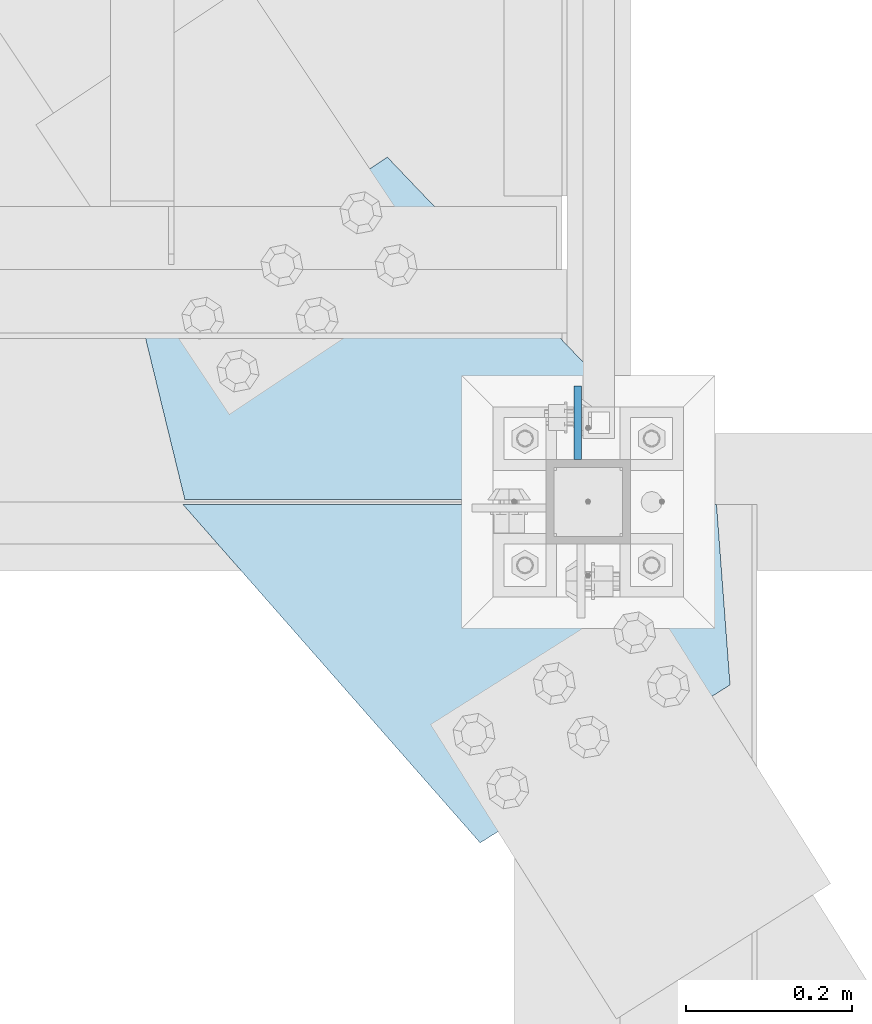
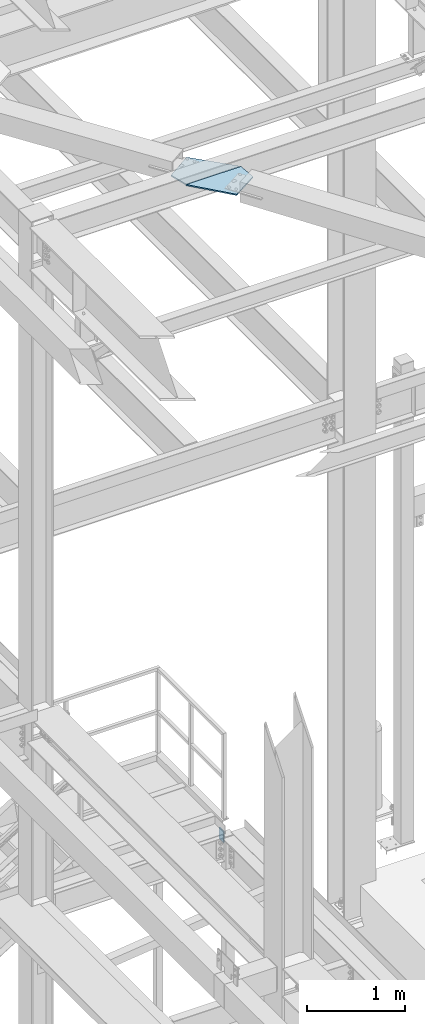
# One storey, part 3416 of 3843: 3 plates, 2 elements without a shape of their own.
"""IFC2X3 building model written with IfcOpenShell, lengths in millimetres."""

from ifc_helpers import new_model, si_unit, frame, origin_with_axes, place, context, subcontext, project, spatial, faceted_brep, material, type_object, element, aggregate, save


model = new_model("IFC2X3")

# Units and contexts
model_context = context("Model", 3, precision=1e-05, world=origin_with_axes())
body_context = subcontext(model_context, "Body", "Model", "MODEL_VIEW")
ifc_project = project(units=[si_unit("LENGTHUNIT", "METRE", prefix="MILLI"), si_unit("AREAUNIT", "SQUARE_METRE"), si_unit("VOLUMEUNIT", "CUBIC_METRE"), si_unit("MASSUNIT", "GRAM", prefix="KILO"), si_unit("TIMEUNIT", "SECOND"), si_unit("PLANEANGLEUNIT", "RADIAN"), si_unit("SOLIDANGLEUNIT", "STERADIAN"), si_unit("THERMODYNAMICTEMPERATUREUNIT", "DEGREE_CELSIUS"), si_unit("LUMINOUSINTENSITYUNIT", "LUMEN")], contexts=[model_context])

# Site, building, storey
site_placement = place(None, origin_with_axes())
site = spatial("IfcSite", under=ifc_project, at=site_placement, CompositionType="ELEMENT")
building_placement = place(site_placement, origin_with_axes())
building = spatial("IfcBuilding", under=site, at=building_placement, Name="Undefined", CompositionType="ELEMENT")
storey_placement = place(building_placement, origin_with_axes())
storey = spatial("IfcBuildingStorey", under=building, at=storey_placement, Name="Undefined", CompositionType="ELEMENT", Elevation=0.0)

# Assembly, plate
assembly_1_placement = place(storey_placement, origin_with_axes())
assembly_1 = element("IfcElementAssembly", 1, at=assembly_1_placement, inside=storey, Name="COLUMN", AssemblyPlace="NOTDEFINED", PredefinedType="RIGID_FRAME")
ifc_material = material(Name="STEEL/A572-50")
plate_type_1 = type_object("IfcPlateType", PredefinedType="NOTDEFINED")
plate_1_placement = place(assembly_1_placement, frame((38808.0254993375, 89166.7, 34029.65), z_axis=(0.0, 1.0, 0.0), x_axis=(0.0, 0.0, -1.0)))
plate_1 = element("IfcPlate", 2, at=plate_1_placement, type_object=plate_type_1, material=ifc_material, Name="PLATE", context=body_context, shape_type="Brep", body=[
    faceted_brep([(0.0, -4.76249999999709, 0.0), (0.0, -4.76249999999709, 88.9000015258789), (0.0, 4.76249999999709, 88.9000015258789), (0.0, 4.76249999999709, 0.0), (139.699999999997, -4.76249999999709, 88.8999999999942), (139.699999999997, 4.76249999999709, 88.8999999999942), (139.699999999997, -4.76249999999709, 0.0), (139.699999999997, 4.76249999999709, 0.0)], [[[0, 1, 2, 3]], [[1, 4, 5, 2]], [[4, 6, 7, 5]], [[6, 0, 3, 7]], [[5, 7, 3, 2]], [[6, 4, 1, 0]]]),
])
aggregate(assembly_1, [plate_1])

# Assembly, plates
assembly_2_placement = place(storey_placement, origin_with_axes())
assembly_2 = element("IfcElementAssembly", 3, at=assembly_2_placement, inside=storey, Name="BEAM", AssemblyPlace="NOTDEFINED", PredefinedType="RIGID_FRAME")
plate_type_2 = type_object("IfcPlateType", PredefinedType="NOTDEFINED")
plate_2_placement = place(assembly_2_placement, frame((38335.3893008074, 89119.0749999997, 42238.6125), z_axis=(0.0, 1.0, 0.0), x_axis=(1.0, 0.0, 0.0)))
plate_2 = element("IfcPlate", 4, at=plate_2_placement, type_object=plate_type_2, material=ifc_material, context=body_context, shape_type="Brep", body=[
    faceted_brep([(0.0, -7.9375, 0.0), (-52.2050263152705, -7.9375, 214.315079872962), (-52.2050263152705, 7.9375, 214.315079872962), (0.0, 7.9375, 0.0), (243.672058351265, -7.9375, 411.566469650657), (243.672058351265, 7.9375, 411.566469650657), (636.837040561681, -7.9375, 0.0), (636.837040561681, 7.9375, 0.0)], [[[0, 1, 2, 3]], [[1, 4, 5, 2]], [[4, 6, 7, 5]], [[6, 0, 3, 7]], [[5, 7, 3, 2]], [[6, 4, 1, 0]]]),
])
plate_type_3 = type_object("IfcPlateType", PredefinedType="NOTDEFINED")
plate_3_placement = place(assembly_2_placement, frame((38974.9831127857, 89112.7250000168, 42238.6125), z_axis=(0.0, -1.0, 0.0), x_axis=(-1.0, 0.0, 0.0)))
plate_3 = element("IfcPlate", 5, at=plate_3_placement, type_object=plate_type_3, material=ifc_material, context=body_context, shape_type="Brep", body=[
    faceted_brep([(0.0, -7.9375, 0.0), (-16.2805532187413, -7.9375, 216.8571582679), (-16.2805532187413, 7.9375, 216.8571582679), (0.0, 7.9375, 0.0), (284.316351412213, -7.9375, 406.83837030291), (284.316351412213, 7.9375, 406.83837030291), (641.649906506813, -7.9375, 0.0), (641.649906506813, 7.9375, 0.0)], [[[0, 1, 2, 3]], [[1, 4, 5, 2]], [[4, 6, 7, 5]], [[6, 0, 3, 7]], [[5, 7, 3, 2]], [[6, 4, 1, 0]]]),
])
aggregate(assembly_2, [plate_2, plate_3])

save(model, "model.ifc")
